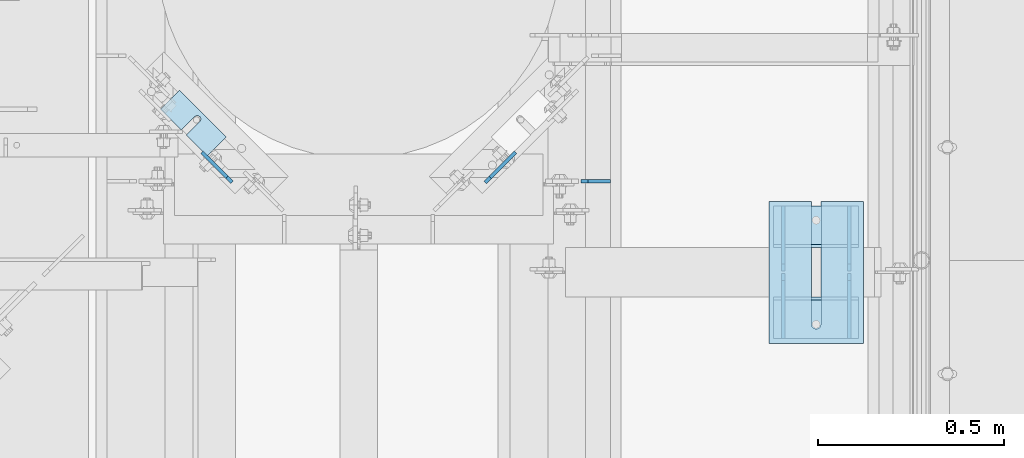
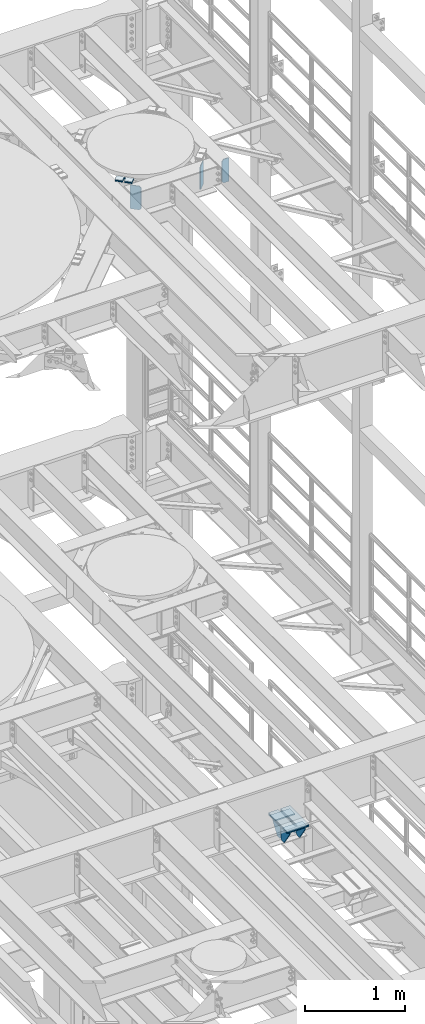
# One storey, part 1792 of 1876: 18 plates, 12 elements without a shape of their own.
"""IFC2X3 building model written with IfcOpenShell, lengths in millimetres."""

from ifc_helpers import new_model, si_unit, frame, origin_with_axes, place, context, subcontext, project, spatial, faceted_brep, material, type_object, element, aggregate, save


model = new_model("IFC2X3")

# Units and contexts
model_context = context("Model", 3, precision=1e-05, world=origin_with_axes())
body_context = subcontext(model_context, "Body", "Model", "MODEL_VIEW")
ifc_project = project(units=[si_unit("LENGTHUNIT", "METRE", prefix="MILLI"), si_unit("AREAUNIT", "SQUARE_METRE"), si_unit("VOLUMEUNIT", "CUBIC_METRE"), si_unit("MASSUNIT", "GRAM", prefix="KILO"), si_unit("TIMEUNIT", "SECOND"), si_unit("PLANEANGLEUNIT", "RADIAN"), si_unit("SOLIDANGLEUNIT", "STERADIAN"), si_unit("THERMODYNAMICTEMPERATUREUNIT", "DEGREE_CELSIUS"), si_unit("LUMINOUSINTENSITYUNIT", "LUMEN")], contexts=[model_context])

# Site, building, storey
site_placement = place(None, origin_with_axes())
site = spatial("IfcSite", under=ifc_project, at=site_placement, CompositionType="ELEMENT")
building_placement = place(site_placement, origin_with_axes())
building = spatial("IfcBuilding", under=site, at=building_placement, Name="Undefined", CompositionType="ELEMENT")
storey_placement = place(building_placement, origin_with_axes())
storey = spatial("IfcBuildingStorey", under=building, at=storey_placement, Name="Undefined", CompositionType="ELEMENT", Elevation=0.0)

# Assembly, plate
assembly_1_placement = place(storey_placement, origin_with_axes())
assembly_1 = element("IfcElementAssembly", 1, at=assembly_1_placement, inside=storey, Name="BEAM", AssemblyPlace="NOTDEFINED", PredefinedType="RIGID_FRAME")
ifc_material = material(Name="STEEL/A36")
plate_type_1 = type_object("IfcPlateType", PredefinedType="NOTDEFINED")
plate_1_placement = place(assembly_1_placement, frame((6705.6, 10880.6726064376, 13007.975), z_axis=(0.0, 0.0, 1.0), x_axis=(1.0, 0.0, 0.0)))
plate_1 = element("IfcPlate", 2, at=plate_1_placement, type_object=plate_type_1, material=ifc_material, Name="PLATE", context=body_context, shape_type="Brep", body=[
    faceted_brep([(0.0, -4.76249999999982, 19.0499992370605), (0.0, -4.76250000000073, 269.874988555908), (0.0, 4.76250000000073, 269.874988555908), (0.0, 4.76249999999982, 19.0499992370605), (19.0499992370605, -4.76250000000073, 288.924987792969), (19.0499992370605, 4.76250000000073, 288.924987792969), (79.375, -4.76250000000073, 288.924987792969), (79.375, 4.76250000000073, 288.924987792969), (79.375, -4.76250000000073, 0.0), (79.375, 4.76250000000073, 0.0), (19.0499992370605, -4.76249999999982, 0.0), (19.0499992370605, 4.76249999999982, 0.0)], [[[0, 1, 2, 3]], [[1, 4, 5, 2]], [[4, 6, 7, 5]], [[6, 8, 9, 7]], [[8, 10, 11, 9]], [[10, 0, 3, 11]], [[5, 7, 9, 11, 3, 2]], [[10, 8, 6, 4, 1, 0]]]),
])
aggregate(assembly_1, [plate_1])

# Assembly, plates
assembly_2_placement = place(storey_placement, origin_with_axes())
assembly_2 = element("IfcElementAssembly", 3, at=assembly_2_placement, inside=storey, Name="BEAM", AssemblyPlace="NOTDEFINED", PredefinedType="RIGID_FRAME")
plate_type_2 = type_object("IfcPlateType", PredefinedType="NOTDEFINED")
plate_2_placement = place(assembly_2_placement, frame((6448.56805843841, 10877.6893490729, 13009.5625), z_axis=(0.0, 0.0, 1.0), x_axis=(0.707106781186548, 0.707106781186547, 0.0)))
plate_2 = element("IfcPlate", 4, at=plate_2_placement, type_object=plate_type_2, material=ifc_material, Name="PLATE", context=body_context, shape_type="Brep", body=[
    faceted_brep([(0.0, -4.76249999999982, 19.0499992370605), (0.0, -4.76249999999982, 271.462512969971), (0.0, 4.76249999999982, 271.462512969971), (0.0, 4.76249999999982, 19.0499992370605), (19.0499992370605, -4.76249999999982, 290.512512207031), (19.0499992370605, 4.76249999999982, 290.512512207031), (114.300003051778, -4.76250000000027, 290.512512207031), (114.300003051778, 4.76250000000118, 290.512512207031), (114.300003051758, -4.76249999999999, 0.0), (114.300003051758, 4.76249999999999, 0.0), (19.0499992370605, -4.76249999999982, 0.0), (19.0499992370605, 4.76249999999982, 0.0)], [[[0, 1, 2, 3]], [[1, 4, 5, 2]], [[4, 6, 7, 5]], [[6, 8, 9, 7]], [[8, 10, 11, 9]], [[10, 0, 3, 11]], [[5, 7, 9, 11, 3, 2]], [[10, 8, 6, 4, 1, 0]]]),
])
plate_3_placement = place(assembly_2_placement, frame((5768.83194155936, 10877.6893490729, 13009.5625), z_axis=(0.0, 0.0, 1.0), x_axis=(-0.707106781186548, 0.707106781186547, 0.0)))
plate_3 = element("IfcPlate", 5, at=plate_3_placement, type_object=plate_type_2, material=ifc_material, Name="PLATE", context=body_context, shape_type="Brep", body=[
    faceted_brep([(0.0, -4.76249999999982, 19.0499992370605), (0.0, -4.76249999999982, 271.462512969971), (0.0, 4.76249999999982, 271.462512969971), (0.0, 4.76249999999982, 19.0499992370605), (19.0499992370605, -4.76249999999982, 290.512512207031), (19.0499992370605, 4.76249999999982, 290.512512207031), (114.300003051778, -4.76250000000027, 290.512512207031), (114.300003051778, 4.76250000000118, 290.512512207031), (114.300003051758, -4.76249999999999, 0.0), (114.300003051758, 4.76249999999999, 0.0), (19.0499992370605, -4.76249999999982, 0.0), (19.0499992370605, 4.76249999999982, 0.0)], [[[0, 1, 2, 3]], [[1, 4, 5, 2]], [[4, 6, 7, 5]], [[6, 8, 9, 7]], [[8, 10, 11, 9]], [[10, 0, 3, 11]], [[5, 7, 9, 11, 3, 2]], [[10, 8, 6, 4, 1, 0]]]),
])
aggregate(assembly_2, [plate_2, plate_3])

# Assembly, plate
assembly_3_placement = place(storey_placement, origin_with_axes())
assembly_3 = element("IfcElementAssembly", 6, at=assembly_3_placement, inside=storey, Name="SHIM PLATE", AssemblyPlace="NOTDEFINED", PredefinedType="RIGID_FRAME")
plate_type_3 = type_object("IfcPlateType", PredefinedType="NOTDEFINED")
plate_4_placement = place(assembly_3_placement, frame((7464.42584540703, 10826.4112935512, 5154.6115), z_axis=(0.0, -1.0, 0.0), x_axis=(-1.0, 0.0, 0.0)))
plate_4 = element("IfcPlate", 7, at=plate_4_placement, type_object=plate_type_3, material=ifc_material, Name="SHIM PLATE", context=body_context, shape_type="Brep", body=[
    faceted_brep([(114.225666651796, -1.58749999999964, 3.8198777474463e-11), (114.225666651796, 1.58749999999964, 3.8198777474463e-11), (114.225667968606, 1.58749999999964, 330.200590822098), (114.225667968606, -1.58749999999964, 330.200590822098), (115.927140877607, 1.58749999999964, 336.550596048311), (115.927140877607, -1.58749999999964, 336.550596048311), (120.575663766391, 1.58749999999964, 341.199123921255), (120.575663766391, -1.58749999999964, 341.199123921255), (126.925667168282, 1.58749999999964, 342.90060363874), (126.925667168282, -1.58749999999964, 342.90060363874), (133.275670733512, 1.58749999999964, 341.199124530865), (133.275670733512, -1.58749999999964, 341.199124530865), (137.924194068548, 1.58749999999964, 336.550597104191), (137.924194068548, -1.58749999999964, 336.550597104191), (139.625667587137, -1.58749999999964, 330.200592041319), (139.625667587137, 1.58749999999964, 330.200592041319), (139.625683436465, 1.58749999999964, 4.72937244921923e-11), (139.625683436465, -1.58749999999964, 4.72937244921923e-11), (9.09494701772928e-13, -1.58750000000146, 4.54747350886464e-13), (-1.83084230229724e-05, -1.58749999999964, 381.006103515625), (-1.83084230229724e-05, 1.58749999999964, 381.006103515625), (9.09494701772928e-13, 1.58750000000146, 4.54747350886464e-13), (253.999526977692, -1.58749999999964, 381.006103515754), (253.999526977692, 1.58749999999964, 381.006103515754), (253.999542236328, -1.58750000000146, 6.16182660451159e-11), (253.999542236328, 1.58750000000146, 6.16182660451159e-11)], [[[0, 1, 2, 3]], [[3, 2, 4, 5]], [[5, 4, 6, 7]], [[7, 6, 8, 9]], [[9, 8, 10, 11]], [[11, 10, 12, 13]], [[14, 15, 16, 17]], [[13, 12, 15, 14]], [[18, 19, 20, 21]], [[19, 22, 23, 20]], [[22, 24, 25, 23]], [[25, 24, 17, 16]], [[10, 8, 6, 4, 2, 1, 21, 20, 23, 25, 16, 15, 12]], [[18, 21, 1, 0]], [[24, 22, 19, 18, 0, 3, 5, 7, 9, 11, 13, 14, 17]]]),
])
aggregate(assembly_3, [plate_4])

assembly_4_placement = place(storey_placement, origin_with_axes())
assembly_4 = element("IfcElementAssembly", 8, at=assembly_4_placement, inside=storey, Name="SHIM PLATE", AssemblyPlace="NOTDEFINED", PredefinedType="RIGID_FRAME")
plate_5_placement = place(assembly_4_placement, frame((7464.42584540703, 10826.4112732067, 5151.4365), z_axis=(0.0, -1.0, 0.0), x_axis=(-1.0, 0.0, 0.0)))
plate_5 = element("IfcPlate", 9, at=plate_5_placement, type_object=plate_type_3, material=ifc_material, Name="SHIM PLATE", context=body_context, shape_type="Brep", body=[
    faceted_brep([(114.225666651796, -1.58749999999964, 3.8198777474463e-11), (114.225666651796, 1.58749999999964, 3.8198777474463e-11), (114.225667968606, 1.58749999999964, 330.200590822098), (114.225667968606, -1.58749999999964, 330.200590822098), (115.927140877607, 1.58749999999964, 336.550596048311), (115.927140877607, -1.58749999999964, 336.550596048311), (120.575663766391, 1.58749999999964, 341.199123921255), (120.575663766391, -1.58749999999964, 341.199123921255), (126.925667168282, 1.58749999999964, 342.90060363874), (126.925667168282, -1.58749999999964, 342.90060363874), (133.275670733512, 1.58749999999964, 341.199124530865), (133.275670733512, -1.58749999999964, 341.199124530865), (137.924194068548, 1.58749999999964, 336.550597104191), (137.924194068548, -1.58749999999964, 336.550597104191), (139.625667587137, -1.58749999999964, 330.200592041319), (139.625667587137, 1.58749999999964, 330.200592041319), (139.625683436465, 1.58749999999964, 4.72937244921923e-11), (139.625683436465, -1.58749999999964, 4.72937244921923e-11), (9.09494701772928e-13, -1.58750000000146, 4.54747350886464e-13), (-1.83084230229724e-05, -1.58749999999964, 381.006103515625), (-1.83084230229724e-05, 1.58749999999964, 381.006103515625), (9.09494701772928e-13, 1.58750000000146, 4.54747350886464e-13), (253.999526977692, -1.58749999999964, 381.006103515754), (253.999526977692, 1.58749999999964, 381.006103515754), (253.999542236328, -1.58750000000146, 6.16182660451159e-11), (253.999542236328, 1.58750000000146, 6.16182660451159e-11)], [[[0, 1, 2, 3]], [[3, 2, 4, 5]], [[5, 4, 6, 7]], [[7, 6, 8, 9]], [[9, 8, 10, 11]], [[11, 10, 12, 13]], [[14, 15, 16, 17]], [[13, 12, 15, 14]], [[18, 19, 20, 21]], [[19, 22, 23, 20]], [[22, 24, 25, 23]], [[25, 24, 17, 16]], [[10, 8, 6, 4, 2, 1, 21, 20, 23, 25, 16, 15, 12]], [[18, 21, 1, 0]], [[24, 22, 19, 18, 0, 3, 5, 7, 9, 11, 13, 14, 17]]]),
])
aggregate(assembly_4, [plate_5])

assembly_5_placement = place(storey_placement, origin_with_axes())
assembly_5 = element("IfcElementAssembly", 10, at=assembly_5_placement, inside=storey, Name="SHIM PLATE", AssemblyPlace="NOTDEFINED", PredefinedType="RIGID_FRAME")
plate_type_4 = type_object("IfcPlateType", PredefinedType="NOTDEFINED")
plate_6_placement = place(assembly_5_placement, frame((7464.42584540703, 10826.4113138957, 5156.9925), z_axis=(0.0, -1.0, 0.0), x_axis=(-1.0, 0.0, 0.0)))
plate_6 = element("IfcPlate", 11, at=plate_6_placement, type_object=plate_type_4, material=ifc_material, Name="SHIM PLATE", context=body_context, shape_type="Brep", body=[
    faceted_brep([(114.225666651797, -0.793499999999767, 3.8198777474463e-11), (114.225666651797, 0.793499999999767, 3.8198777474463e-11), (114.225667968606, 0.793499999999767, 330.200590822098), (114.225667968606, -0.793499999999767, 330.200590822098), (115.927140877607, 0.793499999999767, 336.550596048311), (115.927140877607, -0.793499999999767, 336.550596048311), (120.575663766392, 0.793499999999767, 341.199123921255), (120.575663766392, -0.793499999999767, 341.199123921255), (126.925667168282, 0.793499999999767, 342.90060363874), (126.925667168282, -0.793499999999767, 342.90060363874), (133.275670733513, 0.793499999999767, 341.199124530865), (133.275670733513, -0.793499999999767, 341.199124530865), (137.924194068548, 0.793499999999767, 336.550597104191), (137.924194068548, -0.793499999999767, 336.550597104191), (139.625667587137, -0.793499999999767, 330.200592041319), (139.625667587137, 0.793499999999767, 330.200592041319), (139.625683436465, 0.793499999999767, 4.72937244921923e-11), (139.625683436465, -0.793499999999767, 4.72937244921923e-11), (9.09494701772928e-13, -0.793499999999767, 0.0), (-1.83080774149857e-05, -0.793499999999767, 381.006103515625), (-1.83080774149857e-05, 0.793499999999767, 381.006103515625), (9.09494701772928e-13, 0.793499999999767, 0.0), (253.999526977692, -0.793499999999767, 381.006103515754), (253.999526977692, 0.793499999999767, 381.006103515754), (253.999542236328, -0.793499999999767, 6.16182660451159e-11), (253.999542236328, 0.793499999999767, 6.16182660451159e-11)], [[[0, 1, 2, 3]], [[3, 2, 4, 5]], [[5, 4, 6, 7]], [[7, 6, 8, 9]], [[9, 8, 10, 11]], [[11, 10, 12, 13]], [[14, 15, 16, 17]], [[13, 12, 15, 14]], [[18, 19, 20, 21]], [[19, 22, 23, 20]], [[22, 24, 25, 23]], [[25, 24, 17, 16]], [[10, 8, 6, 4, 2, 1, 21, 20, 23, 25, 16, 15, 12]], [[18, 21, 1, 0]], [[24, 22, 19, 18, 0, 3, 5, 7, 9, 11, 13, 14, 17]]]),
])
aggregate(assembly_5, [plate_6])

assembly_6_placement = place(storey_placement, origin_with_axes())
assembly_6 = element("IfcElementAssembly", 12, at=assembly_6_placement, inside=storey, Name="SHIM PLATE", AssemblyPlace="NOTDEFINED", PredefinedType="RIGID_FRAME")
plate_type_5 = type_object("IfcPlateType", PredefinedType="NOTDEFINED")
plate_7_placement = place(assembly_6_placement, frame((7464.42584540703, 10826.4112528623, 5147.468), z_axis=(0.0, -1.0, 0.0), x_axis=(-1.0, 0.0, 0.0)))
plate_7 = element("IfcPlate", 13, at=plate_7_placement, type_object=plate_type_5, material=ifc_material, Name="SHIM PLATE", context=body_context, shape_type="Brep", body=[
    faceted_brep([(114.225666651796, -2.38100000000031, 3.8198777474463e-11), (114.225666651796, 2.38100000000031, 3.8198777474463e-11), (114.225667968606, 2.38100000000031, 330.200590822098), (114.225667968606, -2.38100000000031, 330.200590822098), (115.927140877607, 2.38100000000031, 336.550596048311), (115.927140877607, -2.38100000000031, 336.550596048311), (120.575663766391, 2.38100000000031, 341.199123921255), (120.575663766391, -2.38100000000031, 341.199123921255), (126.925667168282, 2.38100000000031, 342.90060363874), (126.925667168282, -2.38100000000031, 342.90060363874), (133.275670733512, 2.38100000000031, 341.199124530865), (133.275670733512, -2.38100000000031, 341.199124530865), (137.924194068548, 2.38100000000031, 336.550597104191), (137.924194068548, -2.38100000000031, 336.550597104191), (139.625667587137, -2.38100000000031, 330.200592041319), (139.625667587137, 2.38100000000031, 330.200592041319), (139.625683436464, 2.38100000000031, 4.72937244921923e-11), (139.625683436464, -2.38100000000031, 4.72937244921923e-11), (0.0, -2.38100000000122, 4.54747350886464e-13), (-1.83087686309591e-05, -2.38100000000031, 381.006103515625), (-1.83087686309591e-05, 2.38100000000031, 381.006103515625), (0.0, 2.38100000000122, 4.54747350886464e-13), (253.999526977692, -2.38100000000031, 381.006103515754), (253.999526977692, 2.38100000000031, 381.006103515754), (253.999542236328, -2.38100000000122, 6.16182660451159e-11), (253.999542236328, 2.38100000000122, 6.16182660451159e-11)], [[[0, 1, 2, 3]], [[3, 2, 4, 5]], [[5, 4, 6, 7]], [[7, 6, 8, 9]], [[9, 8, 10, 11]], [[11, 10, 12, 13]], [[14, 15, 16, 17]], [[13, 12, 15, 14]], [[18, 19, 20, 21]], [[19, 22, 23, 20]], [[22, 24, 25, 23]], [[25, 24, 17, 16]], [[10, 8, 6, 4, 2, 1, 21, 20, 23, 25, 16, 15, 12]], [[18, 21, 1, 0]], [[24, 22, 19, 18, 0, 3, 5, 7, 9, 11, 13, 14, 17]]]),
])
aggregate(assembly_6, [plate_7])

assembly_7_placement = place(storey_placement, origin_with_axes())
assembly_7 = element("IfcElementAssembly", 14, at=assembly_7_placement, inside=storey, Name="SHIM PLATE", AssemblyPlace="NOTDEFINED", PredefinedType="RIGID_FRAME")
plate_8_placement = place(assembly_7_placement, frame((7464.42584540703, 10826.4112325178, 5142.706), z_axis=(0.0, -1.0, 0.0), x_axis=(-1.0, 0.0, 0.0)))
plate_8 = element("IfcPlate", 15, at=plate_8_placement, type_object=plate_type_5, material=ifc_material, Name="SHIM PLATE", context=body_context, shape_type="Brep", body=[
    faceted_brep([(114.225666651796, -2.38100000000031, 3.8198777474463e-11), (114.225666651796, 2.38100000000031, 3.8198777474463e-11), (114.225667968606, 2.38100000000031, 330.200590822098), (114.225667968606, -2.38100000000031, 330.200590822098), (115.927140877607, 2.38100000000031, 336.550596048311), (115.927140877607, -2.38100000000031, 336.550596048311), (120.575663766391, 2.38100000000031, 341.199123921255), (120.575663766391, -2.38100000000031, 341.199123921255), (126.925667168282, 2.38100000000031, 342.90060363874), (126.925667168282, -2.38100000000031, 342.90060363874), (133.275670733512, 2.38100000000031, 341.199124530865), (133.275670733512, -2.38100000000031, 341.199124530865), (137.924194068548, 2.38100000000031, 336.550597104191), (137.924194068548, -2.38100000000031, 336.550597104191), (139.625667587137, -2.38100000000031, 330.200592041319), (139.625667587137, 2.38100000000031, 330.200592041319), (139.625683436464, 2.38100000000031, 4.72937244921923e-11), (139.625683436464, -2.38100000000031, 4.72937244921923e-11), (0.0, -2.38100000000122, 4.54747350886464e-13), (-1.83087686309591e-05, -2.38100000000031, 381.006103515625), (-1.83087686309591e-05, 2.38100000000031, 381.006103515625), (0.0, 2.38100000000122, 4.54747350886464e-13), (253.999526977692, -2.38100000000031, 381.006103515754), (253.999526977692, 2.38100000000031, 381.006103515754), (253.999542236328, -2.38100000000122, 6.16182660451159e-11), (253.999542236328, 2.38100000000122, 6.16182660451159e-11)], [[[0, 1, 2, 3]], [[3, 2, 4, 5]], [[5, 4, 6, 7]], [[7, 6, 8, 9]], [[9, 8, 10, 11]], [[11, 10, 12, 13]], [[14, 15, 16, 17]], [[13, 12, 15, 14]], [[18, 19, 20, 21]], [[19, 22, 23, 20]], [[22, 24, 25, 23]], [[25, 24, 17, 16]], [[10, 8, 6, 4, 2, 1, 21, 20, 23, 25, 16, 15, 12]], [[18, 21, 1, 0]], [[24, 22, 19, 18, 0, 3, 5, 7, 9, 11, 13, 14, 17]]]),
])
aggregate(assembly_7, [plate_8])

assembly_8_placement = place(storey_placement, origin_with_axes())
assembly_8 = element("IfcElementAssembly", 16, at=assembly_8_placement, inside=storey, Name="SHIM PLATE", AssemblyPlace="NOTDEFINED", PredefinedType="RIGID_FRAME")
plate_type_6 = type_object("IfcPlateType", PredefinedType="NOTDEFINED")
plate_9_placement = place(assembly_8_placement, frame((7464.42584540703, 10826.4112121733, 5135.5625), z_axis=(0.0, -1.0, 0.0), x_axis=(-1.0, 0.0, 0.0)))
plate_9 = element("IfcPlate", 17, at=plate_9_placement, type_object=plate_type_6, material=ifc_material, Name="SHIM PLATE", context=body_context, shape_type="Brep", body=[
    faceted_brep([(114.225666651796, -4.76249999999982, 3.8198777474463e-11), (114.225666651796, 4.76249999999982, 3.8198777474463e-11), (114.225667968606, 4.76249999999982, 330.200590822098), (114.225667968606, -4.76249999999982, 330.200590822098), (115.927140877606, 4.76249999999982, 336.550596048311), (115.927140877606, -4.76249999999982, 336.550596048311), (120.575663766391, 4.76249999999982, 341.199123921255), (120.575663766391, -4.76249999999982, 341.199123921255), (126.925667168282, 4.76249999999982, 342.90060363874), (126.925667168282, -4.76249999999982, 342.90060363874), (133.275670733512, 4.76249999999982, 341.199124530865), (133.275670733512, -4.76249999999982, 341.199124530865), (137.924194068547, 4.76249999999982, 336.550597104191), (137.924194068547, -4.76249999999982, 336.550597104191), (139.625667587137, -4.76249999999982, 330.200592041319), (139.625667587137, 4.76249999999982, 330.200592041319), (139.625683436464, 4.76249999999982, 4.72937244921923e-11), (139.625683436464, -4.76249999999982, 4.72937244921923e-11), (0.0, -4.76249999999982, 0.0), (-1.83091142389458e-05, -4.76249999999982, 381.006103515625), (-1.83091142389458e-05, 4.76249999999982, 381.006103515625), (0.0, 4.76249999999982, 0.0), (253.999526977692, -4.76249999999982, 381.006103515754), (253.999526977692, 4.76249999999982, 381.006103515754), (253.999542236328, -4.76250000000073, 6.16182660451159e-11), (253.999542236328, 4.76250000000073, 6.16182660451159e-11)], [[[0, 1, 2, 3]], [[3, 2, 4, 5]], [[5, 4, 6, 7]], [[7, 6, 8, 9]], [[9, 8, 10, 11]], [[11, 10, 12, 13]], [[14, 15, 16, 17]], [[13, 12, 15, 14]], [[18, 19, 20, 21]], [[19, 22, 23, 20]], [[22, 24, 25, 23]], [[25, 24, 17, 16]], [[10, 8, 6, 4, 2, 1, 21, 20, 23, 25, 16, 15, 12]], [[18, 21, 1, 0]], [[24, 22, 19, 18, 0, 3, 5, 7, 9, 11, 13, 14, 17]]]),
])
aggregate(assembly_8, [plate_9])

assembly_9_placement = place(storey_placement, origin_with_axes())
assembly_9 = element("IfcElementAssembly", 18, at=assembly_9_placement, inside=storey, Name="SHIM PLATE", AssemblyPlace="NOTDEFINED", PredefinedType="RIGID_FRAME")
plate_type_7 = type_object("IfcPlateType", PredefinedType="NOTDEFINED")
plate_10_placement = place(assembly_9_placement, frame((5752.82773957831, 10999.2121093142, 13326.268), z_axis=(-0.707095463095965, 0.707118099095973, 0.0), x_axis=(-0.707118099095974, -0.707095463095965, 0.0)))
plate_10 = element("IfcPlate", 19, at=plate_10_placement, type_object=plate_type_7, material=ifc_material, Name="SHIM PLATE", context=body_context, shape_type="Brep", body=[
    faceted_brep([(71.4045474198501, -2.3809999999994, 79.3704623494173), (71.4045474198501, 2.3809999999994, 79.3704623494173), (23.7781246776667, 2.3809999999994, 79.3704112277633), (23.7781246776667, -2.3809999999994, 79.3704112277633), (17.7435939503794, 2.3809999999994, 79.5232321855551), (17.7435939503794, -2.3809999999994, 79.5232321855551), (12.9144746082547, 2.3809999999994, 83.1451821745982), (12.9144746082547, -2.3809999999994, 83.1451821745982), (11.0782662795191, 2.3809999999994, 88.8955955786164), (11.0782662795191, -2.3809999999994, 88.8955955786164), (12.9146418967412, 2.3809999999994, 94.6459555618007), (12.9146418967412, -2.3809999999994, 94.6459555618007), (17.7438666054804, 2.3809999999994, 98.2677650620712), (17.7438666054804, -2.3809999999994, 98.2677650620712), (23.778401776035, 2.3809999999994, 98.4204104651049), (23.778401776035, -2.3809999999994, 98.4204104651049), (71.4046756165262, -2.3809999999994, 98.4204615866142), (71.4045269830367, 2.3809999999994, 98.4204615864551), (71.4046325683794, -2.3809999999994, -9.54969436861575e-12), (0.0, -2.38100000000122, 4.54747350886464e-13), (0.0, 2.38100000000122, 4.54747350886464e-13), (71.4046325683794, 2.3809999999994, -9.54969436861575e-12), (0.00273432340873114, -2.3809999999994, 177.792755126891), (0.00273432340873114, 2.3809999999994, 177.792755126891), (71.404441833658, -2.3809999999994, 177.791717529224), (71.404441833658, 2.3809999999994, 177.791717529224)], [[[0, 1, 2, 3]], [[3, 2, 4, 5]], [[5, 4, 6, 7]], [[7, 6, 8, 9]], [[9, 8, 10, 11]], [[11, 10, 12, 13]], [[13, 12, 14, 15]], [[16, 15, 14, 17]], [[18, 19, 20, 21]], [[19, 22, 23, 20]], [[22, 24, 25, 23]], [[25, 24, 16, 17]], [[12, 10, 8, 6, 4, 2, 1, 21, 20, 23, 25, 17, 14]], [[18, 21, 1, 0]], [[24, 22, 19, 18, 0, 3, 5, 7, 9, 11, 13, 15, 16]]]),
])
aggregate(assembly_9, [plate_10])

assembly_10_placement = place(storey_placement, origin_with_axes())
assembly_10 = element("IfcElementAssembly", 20, at=assembly_10_placement, inside=storey, Name="SHIM PLATE", AssemblyPlace="NOTDEFINED", PredefinedType="RIGID_FRAME")
plate_11_placement = place(assembly_10_placement, frame((5752.82773957831, 10999.2121093142, 13321.506), z_axis=(-0.707095463095965, 0.707118099095973, 0.0), x_axis=(-0.707118099095974, -0.707095463095965, 0.0)))
plate_11 = element("IfcPlate", 21, at=plate_11_placement, type_object=plate_type_7, material=ifc_material, Name="SHIM PLATE", context=body_context, shape_type="Brep", body=[
    faceted_brep([(71.4045474198501, -2.3809999999994, 79.3704623494173), (71.4045474198501, 2.3809999999994, 79.3704623494173), (23.7781246776667, 2.3809999999994, 79.3704112277633), (23.7781246776667, -2.3809999999994, 79.3704112277633), (17.7435939503794, 2.3809999999994, 79.5232321855551), (17.7435939503794, -2.3809999999994, 79.5232321855551), (12.9144746082547, 2.3809999999994, 83.1451821745982), (12.9144746082547, -2.3809999999994, 83.1451821745982), (11.0782662795191, 2.3809999999994, 88.8955955786164), (11.0782662795191, -2.3809999999994, 88.8955955786164), (12.9146418967412, 2.3809999999994, 94.6459555618007), (12.9146418967412, -2.3809999999994, 94.6459555618007), (17.7438666054804, 2.3809999999994, 98.2677650620712), (17.7438666054804, -2.3809999999994, 98.2677650620712), (23.778401776035, 2.3809999999994, 98.4204104651049), (23.778401776035, -2.3809999999994, 98.4204104651049), (71.4046756165262, -2.3809999999994, 98.4204615866142), (71.4045269830367, 2.3809999999994, 98.4204615864551), (71.4046325683794, -2.3809999999994, -9.54969436861575e-12), (0.0, -2.38100000000122, 4.54747350886464e-13), (0.0, 2.38100000000122, 4.54747350886464e-13), (71.4046325683794, 2.3809999999994, -9.54969436861575e-12), (0.00273432340873114, -2.3809999999994, 177.792755126891), (0.00273432340873114, 2.3809999999994, 177.792755126891), (71.404441833658, -2.3809999999994, 177.791717529224), (71.404441833658, 2.3809999999994, 177.791717529224)], [[[0, 1, 2, 3]], [[3, 2, 4, 5]], [[5, 4, 6, 7]], [[7, 6, 8, 9]], [[9, 8, 10, 11]], [[11, 10, 12, 13]], [[13, 12, 14, 15]], [[16, 15, 14, 17]], [[18, 19, 20, 21]], [[19, 22, 23, 20]], [[22, 24, 25, 23]], [[25, 24, 16, 17]], [[12, 10, 8, 6, 4, 2, 1, 21, 20, 23, 25, 17, 14]], [[18, 21, 1, 0]], [[24, 22, 19, 18, 0, 3, 5, 7, 9, 11, 13, 15, 16]]]),
])
aggregate(assembly_10, [plate_11])

assembly_11_placement = place(storey_placement, origin_with_axes())
assembly_11 = element("IfcElementAssembly", 22, at=assembly_11_placement, inside=storey, Name="SHIM PLATE", AssemblyPlace="NOTDEFINED", PredefinedType="RIGID_FRAME")
plate_type_8 = type_object("IfcPlateType", PredefinedType="NOTDEFINED")
plate_12_placement = place(assembly_11_placement, frame((5752.82773957831, 10999.2121093142, 13314.3625), z_axis=(-0.707095463095965, 0.707118099095973, 0.0), x_axis=(-0.707118099095974, -0.707095463095965, 0.0)))
plate_12 = element("IfcPlate", 23, at=plate_12_placement, type_object=plate_type_8, material=ifc_material, Name="SHIM PLATE", context=body_context, shape_type="Brep", body=[
    faceted_brep([(71.4045474198483, -4.76250000000073, 79.3704623494177), (71.4045474198483, 4.76250000000073, 79.3704623494177), (23.7781246776667, 4.76250000000073, 79.370411227761), (23.7781246776667, -4.76250000000073, 79.370411227761), (17.7435939503775, 4.76250000000073, 79.5232321855528), (17.7435939503775, -4.76250000000073, 79.5232321855528), (12.9144746082511, 4.76250000000073, 83.1451821745959), (12.9144746082511, -4.76250000000073, 83.1451821745959), (11.0782662795173, 4.76250000000073, 88.8955955786141), (11.0782662795173, -4.76250000000073, 88.8955955786141), (12.9146418967375, 4.76250000000073, 94.6459555617985), (12.9146418967375, -4.76250000000073, 94.6459555617985), (17.7438666054786, 4.76250000000073, 98.2677650620672), (17.7438666054786, -4.76250000000073, 98.2677650620672), (23.7784017760332, 4.76250000000073, 98.4204104651026), (23.7784017760332, -4.76250000000073, 98.4204104651026), (71.4046756165244, -4.76250000000073, 98.4204615866129), (71.4045269830349, 4.76250000000073, 98.4204615864537), (71.4046325683794, -4.76250000000073, -1.18234311230481e-11), (0.0, -4.76249999999982, 0.0), (0.0, 4.76249999999982, 0.0), (71.4046325683794, 4.76250000000073, -1.18234311230481e-11), (0.00273432340145519, -4.76250000000073, 177.792755126889), (0.00273432340145519, 4.76250000000073, 177.792755126889), (71.4044418336543, -4.76250000000073, 177.791717529221), (71.4044418336543, 4.76250000000073, 177.791717529221)], [[[0, 1, 2, 3]], [[3, 2, 4, 5]], [[5, 4, 6, 7]], [[7, 6, 8, 9]], [[9, 8, 10, 11]], [[11, 10, 12, 13]], [[13, 12, 14, 15]], [[16, 15, 14, 17]], [[18, 19, 20, 21]], [[19, 22, 23, 20]], [[22, 24, 25, 23]], [[25, 24, 16, 17]], [[12, 10, 8, 6, 4, 2, 1, 21, 20, 23, 25, 17, 14]], [[18, 21, 1, 0]], [[24, 22, 19, 18, 0, 3, 5, 7, 9, 11, 13, 15, 16]]]),
])
aggregate(assembly_11, [plate_12])

# Assembly, plates
assembly_12_placement = place(storey_placement, origin_with_axes())
assembly_12 = element("IfcElementAssembly", 24, at=assembly_12_placement, inside=storey, Name="BEAM", AssemblyPlace="NOTDEFINED", PredefinedType="RIGID_FRAME")
plate_type_9 = type_object("IfcPlateType", PredefinedType="NOTDEFINED")
plate_13_placement = place(assembly_12_placement, frame((7426.324160994, 10814.3910415649, 5122.862), z_axis=(0.0, -1.0, 0.0), x_axis=(0.0, 0.0, -1.0)))
plate_13 = element("IfcPlate", 25, at=plate_13_placement, type_object=plate_type_9, material=ifc_material, Name="PLATE", context=body_context, shape_type="Brep", body=[
    faceted_brep([(0.0, -4.76249999999982, 0.0), (-0.000445560885964369, -4.76249999999982, 155.916034698565), (-0.000445560885964369, 4.76249999999982, 155.916034698565), (0.0, 4.76249999999982, 0.0), (19.0494992370368, -4.76249999999982, 174.966033935547), (19.0494992370368, 4.76249999999982, 174.966033935547), (171.4494972229, -4.76249999999982, 174.966033935547), (171.4494972229, 4.76249999999982, 174.966033935547), (190.499496459961, -4.76249999999982, 155.916034698486), (190.499496459961, 4.76249999999982, 155.916034698486), (190.499496459961, -4.76249999999982, 111.466041564941), (190.499496459961, 4.76249999999982, 111.466041564941), (25.4000015258789, -4.76250000000073, 0.0), (25.4000015258789, 4.76250000000073, 0.0)], [[[0, 1, 2, 3]], [[1, 4, 5, 2]], [[4, 6, 7, 5]], [[6, 8, 9, 7]], [[8, 10, 11, 9]], [[10, 12, 13, 11]], [[12, 0, 3, 13]], [[5, 7, 9, 11, 13, 3, 2]], [[12, 10, 8, 6, 4, 1, 0]]]),
])
plate_14_placement = place(assembly_12_placement, frame((7248.524160994, 10814.3910415649, 5122.862), z_axis=(0.0, -1.0, 0.0), x_axis=(0.0, 0.0, -1.0)))
plate_14 = element("IfcPlate", 26, at=plate_14_placement, type_object=plate_type_9, material=ifc_material, Name="PLATE", context=body_context, shape_type="Brep", body=[
    faceted_brep([(0.0, -4.76249999999982, 0.0), (-0.000445560885964369, -4.76249999999982, 155.916034698565), (-0.000445560885964369, 4.76249999999982, 155.916034698565), (0.0, 4.76249999999982, 0.0), (19.0494992370368, -4.76249999999982, 174.966033935547), (19.0494992370368, 4.76249999999982, 174.966033935547), (171.4494972229, -4.76249999999982, 174.966033935547), (171.4494972229, 4.76249999999982, 174.966033935547), (190.499496459961, -4.76249999999982, 155.916034698486), (190.499496459961, 4.76249999999982, 155.916034698486), (190.499496459961, -4.76249999999982, 111.466041564941), (190.499496459961, 4.76249999999982, 111.466041564941), (25.4000015258789, -4.76250000000073, 0.0), (25.4000015258789, 4.76250000000073, 0.0)], [[[0, 1, 2, 3]], [[1, 4, 5, 2]], [[4, 6, 7, 5]], [[6, 8, 9, 7]], [[8, 10, 11, 9]], [[10, 12, 13, 11]], [[12, 0, 3, 13]], [[5, 7, 9, 11, 13, 3, 2]], [[12, 10, 8, 6, 4, 1, 0]]]),
])
plate_15_placement = place(assembly_12_placement, frame((7426.324160994, 10458.1089584351, 5122.862), z_axis=(0.0, 1.0, 0.0), x_axis=(0.0, 0.0, -1.0)))
plate_15 = element("IfcPlate", 27, at=plate_15_placement, type_object=plate_type_9, material=ifc_material, Name="PLATE", context=body_context, shape_type="Brep", body=[
    faceted_brep([(0.0, -4.76249999999982, 0.0), (-0.000445560885964369, -4.76249999999982, 155.916034698565), (-0.000445560885964369, 4.76249999999982, 155.916034698565), (0.0, 4.76249999999982, 0.0), (19.0494992370368, -4.76249999999982, 174.966033935547), (19.0494992370368, 4.76249999999982, 174.966033935547), (171.4494972229, -4.76249999999982, 174.966033935547), (171.4494972229, 4.76249999999982, 174.966033935547), (190.499496459961, -4.76249999999982, 155.916034698486), (190.499496459961, 4.76249999999982, 155.916034698486), (190.499496459961, -4.76249999999982, 111.466041564941), (190.499496459961, 4.76249999999982, 111.466041564941), (25.4000015258789, -4.76250000000073, 0.0), (25.4000015258789, 4.76250000000073, 0.0)], [[[0, 1, 2, 3]], [[1, 4, 5, 2]], [[4, 6, 7, 5]], [[6, 8, 9, 7]], [[8, 10, 11, 9]], [[10, 12, 13, 11]], [[12, 0, 3, 13]], [[5, 7, 9, 11, 13, 3, 2]], [[12, 10, 8, 6, 4, 1, 0]]]),
])
plate_16_placement = place(assembly_12_placement, frame((7248.524160994, 10458.1089584351, 5122.862), z_axis=(0.0, 1.0, 0.0), x_axis=(0.0, 0.0, -1.0)))
plate_16 = element("IfcPlate", 28, at=plate_16_placement, type_object=plate_type_9, material=ifc_material, Name="PLATE", context=body_context, shape_type="Brep", body=[
    faceted_brep([(0.0, -4.76249999999982, 0.0), (-0.000445560885964369, -4.76249999999982, 155.916034698565), (-0.000445560885964369, 4.76249999999982, 155.916034698565), (0.0, 4.76249999999982, 0.0), (19.0494992370368, -4.76249999999982, 174.966033935547), (19.0494992370368, 4.76249999999982, 174.966033935547), (171.4494972229, -4.76249999999982, 174.966033935547), (171.4494972229, 4.76249999999982, 174.966033935547), (190.499496459961, -4.76249999999982, 155.916034698486), (190.499496459961, 4.76249999999982, 155.916034698486), (190.499496459961, -4.76249999999982, 111.466041564941), (190.499496459961, 4.76249999999982, 111.466041564941), (25.4000015258789, -4.76250000000073, 0.0), (25.4000015258789, 4.76250000000073, 0.0)], [[[0, 1, 2, 3]], [[1, 4, 5, 2]], [[4, 6, 7, 5]], [[6, 8, 9, 7]], [[8, 10, 11, 9]], [[10, 12, 13, 11]], [[12, 0, 3, 13]], [[5, 7, 9, 11, 13, 3, 2]], [[12, 10, 8, 6, 4, 1, 0]]]),
])
plate_type_10 = type_object("IfcPlateType", PredefinedType="NOTDEFINED")
plate_17_placement = place(assembly_12_placement, frame((7223.12629417271, 10702.925, 5126.831), z_axis=(1.0, 0.0, 0.0), x_axis=(0.0, 1.0, 0.0)))
plate_17 = element("IfcPlate", 29, at=plate_17_placement, type_object=plate_type_10, material=ifc_material, Name="PLATE", context=body_context, shape_type="Brep", body=[
    faceted_brep([(111.466041564941, -3.96900000000005, 228.599548339844), (111.466041564941, -3.96900000000005, 0.0), (111.466041564941, 3.96900000000005, 0.0), (111.466041564941, 3.96900000000005, 228.599548339844), (7.93749999726606, 3.96900000000005, 228.599548339844), (0.0, -3.96900000000005, 228.599548339844), (0.0, -3.96900000000005, 0.0), (7.93749999726606, 3.96900000000005, 0.0)], [[[0, 1, 2, 3]], [[0, 3, 4, 5]], [[1, 0, 5, 6]], [[2, 1, 6, 7]], [[3, 2, 7, 4]], [[6, 5, 4, 7]]]),
])
plate_18_placement = place(assembly_12_placement, frame((7223.12629417271, 10569.575, 5126.831), z_axis=(1.0, 0.0, 0.0), x_axis=(0.0, -1.0, 0.0)))
plate_18 = element("IfcPlate", 30, at=plate_18_placement, type_object=plate_type_10, material=ifc_material, Name="PLATE", context=body_context, shape_type="Brep", body=[
    faceted_brep([(111.466041564941, -3.96900000000005, 228.599548339844), (111.466041564941, -3.96900000000005, 0.0), (111.466041564941, 3.96900000000005, 0.0), (111.466041564941, 3.96900000000005, 228.599548339844), (7.93749999726788, -3.96900000000005, 228.599548339844), (7.93749999726788, -3.96900000000005, 0.0), (0.0, 3.96900000000005, 0.0), (0.0, 3.96900000000005, 228.599548339844)], [[[0, 1, 2, 3]], [[1, 0, 4, 5]], [[2, 1, 5, 6]], [[3, 2, 6, 7]], [[0, 3, 7, 4]], [[6, 5, 4, 7]]]),
])
aggregate(assembly_12, [plate_13, plate_14, plate_17, plate_15, plate_16, plate_18])

save(model, "model.ifc")
